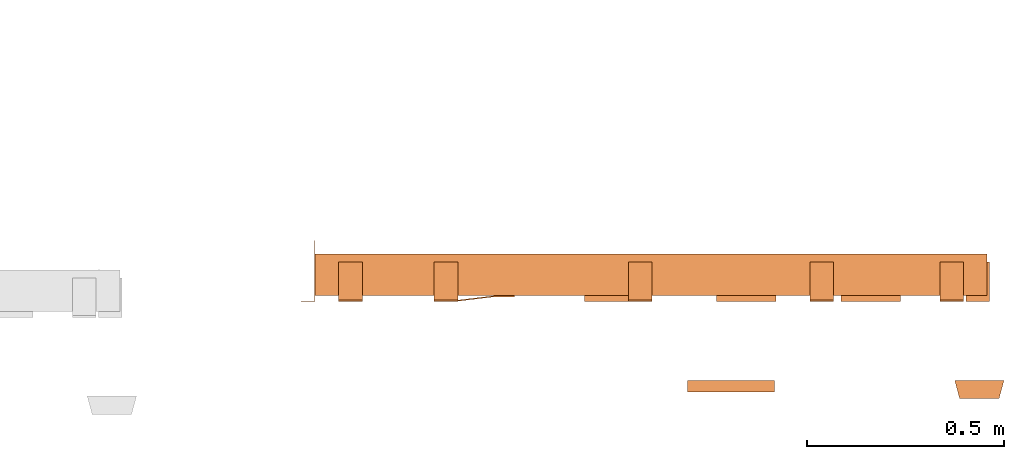
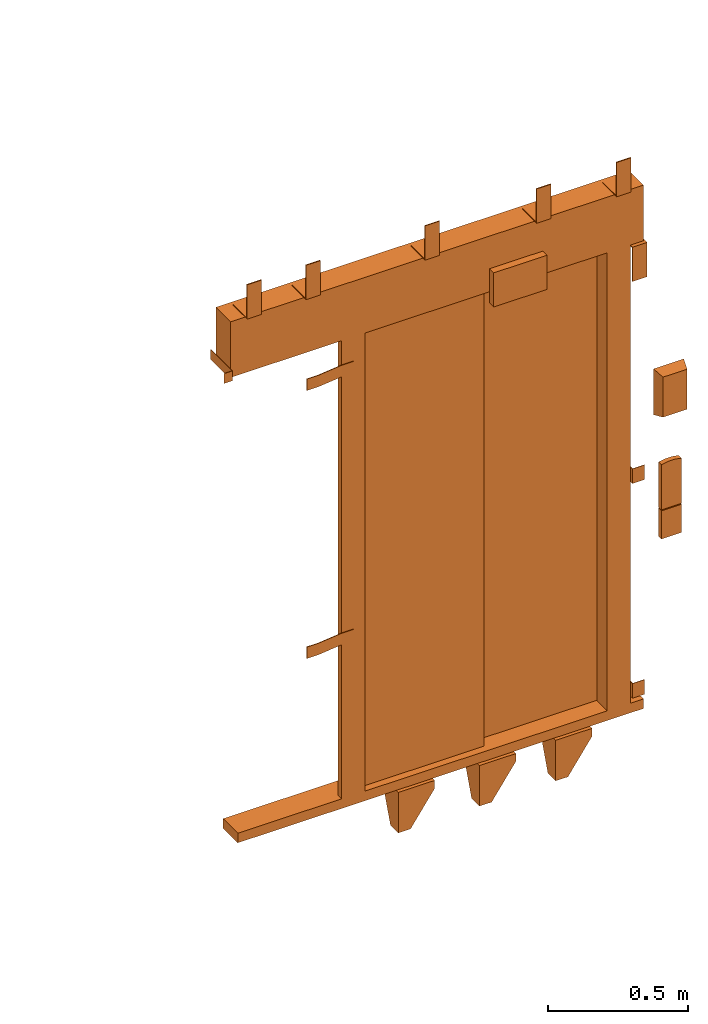
# One storey, part 2 of 2: 1 proxy.
"""IFC2X3 building model written with IfcOpenShell, lengths in millimetres."""

import ifcopenshell
import ifcopenshell.guid

model = None  # the IFC model being written
_history = None  # IfcOwnerHistory: only IFC2X3 demands one
_inside = {}  # id of a spatial element -> (the spatial element, [elements in it])
_under = {}  # id of a project, library or spatial element -> (it, [spatial elements below it])
_declared = {}  # id of a project -> (the project, [libraries it declares])
_typed = {}  # id of a type object -> (the type object, [elements of that type])
_made_of = {}  # id of a material, layer set ... -> (it, [elements and type objects made of it])


def new_model(schema):
    """Start an empty IFC model of exactly this schema.

    Asked for "IFC4X3", IfcOpenShell would pick the latest addendum, in which some entities
    have other attributes; the version numbers below select the first issue.
    IFC2X3 requires an IfcOwnerHistory on every rooted entity: one is made here for all.
    """
    global model, _history
    if schema == "IFC4X3":
        model = ifcopenshell.file(schema_version=(4, 3, 0, 0))
    else:
        model = ifcopenshell.file(schema=schema)
    _inside.clear()
    _under.clear()
    _declared.clear()
    _typed.clear()
    _made_of.clear()
    _history = None
    if model.schema == "IFC2X3":
        org = make("IfcOrganization", Name="unknown")
        user = make(
            "IfcPersonAndOrganization",
            ThePerson=make("IfcPerson", FamilyName="unknown"),
            TheOrganization=org,
        )
        app = make(
            "IfcApplication",
            ApplicationDeveloper=org,
            Version="unknown",
            ApplicationFullName="unknown",
            ApplicationIdentifier="unknown",
        )
        _history = make(
            "IfcOwnerHistory",
            OwningUser=user,
            OwningApplication=app,
            ChangeAction="ADDED",
            CreationDate=0,
        )
    return model


def make(cls, **values):
    """One entity of the class cls with the attributes given. An attribute that is None is left unset."""
    return model.create_entity(
        cls, **{name: value for name, value in values.items() if value is not None}
    )


def entity(cls, *values):
    """Any entity or typed value of the class cls, its attributes in the order of the schema. None: left unset."""
    e = model.create_entity(cls)
    for i, value in enumerate(values):
        if value is not None:
            e[i] = value
    return e


def rooted(cls, **values):
    """An entity with a GlobalId (a new one), such as an element, a storey or a relation."""
    return make(cls, GlobalId=ifcopenshell.guid.new(), OwnerHistory=_history, **values)


def si_unit(unit_type, name, prefix=None):
    """IfcSIUnit, for example si_unit("LENGTHUNIT", "METRE", prefix="MILLI")."""
    return make("IfcSIUnit", UnitType=unit_type, Prefix=prefix, Name=name)


def converted_unit(unit_type, name, factor, base, dimensions=None, offset=None):
    """IfcConversionBasedUnit, such as the inch: factor (a typed value) times the base unit."""
    return make(
        "IfcConversionBasedUnit"
        if offset is None
        else "IfcConversionBasedUnitWithOffset",
        ConversionOffset=offset,
        Dimensions=None
        if dimensions is None
        else entity("IfcDimensionalExponents", *dimensions),
        UnitType=unit_type,
        Name=name,
        ConversionFactor=make(
            "IfcMeasureWithUnit", ValueComponent=factor, UnitComponent=base
        ),
    )


def derived_unit(unit_type, elements):
    """IfcDerivedUnit: a product of units, each with its exponent."""
    return make(
        "IfcDerivedUnit",
        Elements=[
            make("IfcDerivedUnitElement", Unit=unit, Exponent=power)
            for unit, power in elements
        ],
        UnitType=unit_type,
    )


def assignment(units):
    """IfcUnitAssignment: the units of a project."""
    return None if units is None else make("IfcUnitAssignment", Units=units)


def point(xyz):
    """IfcCartesianPoint."""
    return None if xyz is None else make("IfcCartesianPoint", Coordinates=xyz)


def direction(xyz):
    """IfcDirection."""
    return None if xyz is None else make("IfcDirection", DirectionRatios=xyz)


def frame(location, z_axis=None, x_axis=None):
    """IfcAxis2Placement3D, a coordinate frame: its origin and axes. An axis left out is left unset."""
    return make(
        "IfcAxis2Placement3D",
        Location=point(location),
        Axis=direction(z_axis),
        RefDirection=direction(x_axis),
    )


def origin():
    """The frame at (0, 0, 0) with its axes left unset."""
    return frame((0.0, 0.0, 0.0))


def place(relative_to, where):
    """IfcLocalPlacement: puts the frame where relative to a parent placement (None: the world)."""
    return make(
        "IfcLocalPlacement", PlacementRelTo=relative_to, RelativePlacement=where
    )


def context(
    kind, dimensions, precision=None, world=None, true_north=None, identifier=None
):
    """IfcGeometricRepresentationContext, for example the 3D "Model" context."""
    return make(
        "IfcGeometricRepresentationContext",
        ContextIdentifier=identifier,
        ContextType=kind,
        CoordinateSpaceDimension=dimensions,
        Precision=precision,
        WorldCoordinateSystem=world,
        TrueNorth=true_north,
    )


def subcontext(parent, identifier, kind, view, scale=None):
    """IfcGeometricRepresentationSubContext, for example "Body" below "Model"."""
    return make(
        "IfcGeometricRepresentationSubContext",
        ContextIdentifier=identifier,
        ContextType=kind,
        ParentContext=parent,
        TargetScale=scale,
        TargetView=view,
    )


def project(units=None, contexts=None):
    """IfcProject with its units and contexts."""
    return rooted(
        "IfcProject",
        Name="project",
        RepresentationContexts=contexts,
        UnitsInContext=assignment(units),
    )


def spatial(cls, under=None, at=None, **own):
    """A site, building, storey or space (cls), placed at a placement, below another one or the project."""
    s = rooted(cls, ObjectPlacement=at, **own)
    if under is not None:
        _under.setdefault(under.id(), (under, []))[1].append(s)
    return s


def faces_of(points, faces, orient=None, outer=None):
    """IfcFace entities. A face is a list of loops; a loop is a list of indices into points, from 0.

    orient and outer hold one flag for each loop. By default every Orientation is true, the
    first loop of a face is its IfcFaceOuterBound and the others are IfcFaceBound.
    """
    made = []
    for i, loops in enumerate(faces):
        bounds = []
        for j, loop in enumerate(loops):
            is_outer = j == 0 if outer is None else outer[i][j]
            bounds.append(
                make(
                    "IfcFaceOuterBound" if is_outer else "IfcFaceBound",
                    Bound=make("IfcPolyLoop", Polygon=[points[k] for k in loop]),
                    Orientation=True if orient is None else orient[i][j],
                )
            )
        made.append(make("IfcFace", Bounds=bounds))
    return made


def faceted_brep(points, faces, orient=None, outer=None, voids=None):
    """IfcFacetedBrep: a solid bounded by flat faces; with voids (closed shells), ...WithVoids."""
    shared = [point(p) for p in points]
    hull = make("IfcClosedShell", CfsFaces=faces_of(shared, faces, orient, outer))
    if voids is None:
        return make("IfcFacetedBrep", Outer=hull)
    return make(
        "IfcFacetedBrepWithVoids",
        Outer=hull,
        Voids=[
            make(cls, CfsFaces=faces_of(shared, fs, o, b)) for cls, fs, o, b in voids
        ],
    )


def shape(context_of_items, identifier, shape_type, items):
    """IfcShapeRepresentation: the items that make up one representation, for example the "Body"."""
    return make(
        "IfcShapeRepresentation",
        ContextOfItems=context_of_items,
        RepresentationIdentifier=identifier,
        RepresentationType=shape_type,
        Items=items,
    )


def source(mapping_origin, context_of_items, identifier, shape_type, items):
    """IfcRepresentationMap: a shape defined once, which mapped items show again and again."""
    return make(
        "IfcRepresentationMap",
        MappingOrigin=mapping_origin,
        MappedRepresentation=shape(context_of_items, identifier, shape_type, items),
    )


def transform(
    local_origin,
    x_axis=None,
    y_axis=None,
    z_axis=None,
    scale=None,
    scale2=None,
    scale3=None,
    uniform=True,
):
    """IfcCartesianTransformationOperator3D, or its non-uniform kind. x_axis, y_axis, z_axis: its Axis1, 2, 3."""
    if uniform:
        return make(
            "IfcCartesianTransformationOperator3D",
            Axis1=direction(x_axis),
            Axis2=direction(y_axis),
            LocalOrigin=point(local_origin),
            Scale=scale,
            Axis3=direction(z_axis),
        )
    return make(
        "IfcCartesianTransformationOperator3DnonUniform",
        Axis1=direction(x_axis),
        Axis2=direction(y_axis),
        LocalOrigin=point(local_origin),
        Scale=scale,
        Axis3=direction(z_axis),
        Scale2=scale2,
        Scale3=scale3,
    )


def mapped(mapping_source, mapping_target):
    """IfcMappedItem: shows the shape of a source again, moved by a transform."""
    return make(
        "IfcMappedItem", MappingSource=mapping_source, MappingTarget=mapping_target
    )


def material(Name=None, Category=None):
    """IfcMaterial."""
    return make("IfcMaterial", Name=Name, Category=Category)


def made_of(thing, what):
    """Note that an element or type object is made of a material, layer set ...; save() writes the relation."""
    if what is not None:
        _made_of.setdefault(what.id(), (what, []))[1].append(thing)
    return thing


def type_object(cls, material=None, **own):
    """A type object (cls), such as IfcWallType, which elements share."""
    return made_of(rooted(cls, **own), material)


def type_shapes(of_type, sources):
    """Give a type object the sources (RepresentationMaps) that its elements show as mapped items."""
    of_type.RepresentationMaps = sources


def element(
    cls,
    number,
    at=None,
    inside=None,
    cuts=None,
    type_object=None,
    material=None,
    context=None,
    identifier="Body",
    shape_type=None,
    held_by="IfcProductDefinitionShape",
    body=None,
    shapes=None,
    **own,
):
    """One element of the class cls, such as IfcWall. Its Tag is "e" and its number.

    at: its placement. inside: the storey or other place that contains it. cuts: it is an
    opening in that element (IfcRelVoidsElement). A single representation is given by context,
    identifier, shape_type and body (its items); several are given by shapes. held_by: the class
    of the entity that holds the representations. save() writes the other relations.
    """
    e = rooted(cls, Tag="e%d" % number, ObjectPlacement=at, **own)
    if body is not None:
        shapes = [shape(context, identifier, shape_type, body)]
    if shapes is not None:
        e.Representation = make(held_by, Representations=shapes)
    if inside is not None:
        _inside.setdefault(inside.id(), (inside, []))[1].append(e)
    if cuts is not None:
        rooted(
            "IfcRelVoidsElement", RelatingBuildingElement=cuts, RelatedOpeningElement=e
        )
    if type_object is not None:
        _typed.setdefault(type_object.id(), (type_object, []))[1].append(e)
    return made_of(e, material)


def aggregate(whole, parts):
    """IfcRelAggregates: a whole, such as a stair, and the parts it consists of."""
    return rooted("IfcRelAggregates", RelatingObject=whole, RelatedObjects=parts)


def save(model, path):
    """Write the relations noted so far, then the file.

    IfcRelAggregates (storeys below a building ...), IfcRelContainedInSpatialStructure (elements
    in a storey), IfcRelDefinesByType, IfcRelAssociatesMaterial and IfcRelDeclares: one each for
    every whole, place, type object, material and project.
    """
    for whole, parts in _under.values():
        aggregate(whole, parts)
    for where, things in _inside.values():
        rooted(
            "IfcRelContainedInSpatialStructure",
            RelatedElements=things,
            RelatingStructure=where,
        )
    for kind, things in _typed.values():
        rooted("IfcRelDefinesByType", RelatedObjects=things, RelatingType=kind)
    for what, things in _made_of.values():
        rooted("IfcRelAssociatesMaterial", RelatedObjects=things, RelatingMaterial=what)
    for by, libraries in _declared.values():
        rooted("IfcRelDeclares", RelatingContext=by, RelatedDefinitions=libraries)
    model.write(path)


model = new_model("IFC2X3")

# Units and contexts
model_context = context("Model", 3, precision=0.01, world=origin(), true_north=direction((6.12303176911189e-17, 1.0)))
body_context = subcontext(model_context, "Body", "Model", "MODEL_VIEW")
ifc_project = project(units=[si_unit("LENGTHUNIT", "METRE", prefix="MILLI"), si_unit("AREAUNIT", "SQUARE_METRE"), si_unit("VOLUMEUNIT", "CUBIC_METRE"), converted_unit("PLANEANGLEUNIT", "DEGREE", entity("IfcRatioMeasure", 0.0174532925199433), si_unit("PLANEANGLEUNIT", "RADIAN"), dimensions=[0, 0, 0, 0, 0, 0, 0]), si_unit("MASSUNIT", "GRAM", prefix="KILO"), derived_unit("MASSDENSITYUNIT", [(si_unit("MASSUNIT", "GRAM", prefix="KILO"), 1), (si_unit("LENGTHUNIT", "METRE"), -3)]), derived_unit("MOMENTOFINERTIAUNIT", [(si_unit("LENGTHUNIT", "METRE"), 4)]), si_unit("TIMEUNIT", "SECOND"), si_unit("FREQUENCYUNIT", "HERTZ"), si_unit("THERMODYNAMICTEMPERATUREUNIT", "DEGREE_CELSIUS"), derived_unit("THERMALTRANSMITTANCEUNIT", [(si_unit("MASSUNIT", "GRAM", prefix="KILO"), 1), (si_unit("THERMODYNAMICTEMPERATUREUNIT", "KELVIN"), -1), (si_unit("TIMEUNIT", "SECOND"), -3)]), derived_unit("VOLUMETRICFLOWRATEUNIT", [(si_unit("LENGTHUNIT", "METRE"), 3), (si_unit("TIMEUNIT", "SECOND"), -1)]), derived_unit("MASSFLOWRATEUNIT", [(si_unit("MASSUNIT", "GRAM", prefix="KILO"), 1), (si_unit("TIMEUNIT", "SECOND"), -1)]), derived_unit("ROTATIONALFREQUENCYUNIT", [(si_unit("TIMEUNIT", "SECOND"), -1)]), si_unit("ELECTRICCURRENTUNIT", "AMPERE"), si_unit("ELECTRICVOLTAGEUNIT", "VOLT"), si_unit("POWERUNIT", "WATT"), si_unit("FORCEUNIT", "NEWTON", prefix="KILO"), si_unit("ILLUMINANCEUNIT", "LUX"), si_unit("LUMINOUSFLUXUNIT", "LUMEN"), si_unit("LUMINOUSINTENSITYUNIT", "CANDELA"), derived_unit("USERDEFINED", [(si_unit("MASSUNIT", "GRAM", prefix="KILO"), -1), (si_unit("LENGTHUNIT", "METRE"), -2), (si_unit("TIMEUNIT", "SECOND"), 3), (si_unit("LUMINOUSFLUXUNIT", "LUMEN"), 1)]), derived_unit("LINEARVELOCITYUNIT", [(si_unit("LENGTHUNIT", "METRE"), 1), (si_unit("TIMEUNIT", "SECOND"), -1)]), si_unit("PRESSUREUNIT", "PASCAL"), derived_unit("USERDEFINED", [(si_unit("LENGTHUNIT", "METRE"), -2), (si_unit("MASSUNIT", "GRAM", prefix="KILO"), 1), (si_unit("TIMEUNIT", "SECOND"), -2)]), derived_unit("LINEARFORCEUNIT", [(si_unit("MASSUNIT", "GRAM", prefix="KILO"), 1), (si_unit("LENGTHUNIT", "METRE"), 1), (si_unit("TIMEUNIT", "SECOND"), -2), (si_unit("LENGTHUNIT", "METRE"), -1)]), derived_unit("PLANARFORCEUNIT", [(si_unit("MASSUNIT", "GRAM", prefix="KILO"), 1), (si_unit("LENGTHUNIT", "METRE"), 1), (si_unit("TIMEUNIT", "SECOND"), -2), (si_unit("LENGTHUNIT", "METRE"), -2)])], contexts=[model_context])

# Site, building, storey
site_placement = place(None, origin())
site = spatial("IfcSite", under=ifc_project, at=site_placement, CompositionType="ELEMENT")
building_placement = place(site_placement, origin())
building = spatial("IfcBuilding", under=site, at=building_placement, CompositionType="ELEMENT")
storey_placement = place(building_placement, frame((0.0, 0.0, 19800.0)))
storey = spatial("IfcBuildingStorey", under=building, at=storey_placement, CompositionType="ELEMENT", Elevation=19800.0)

# Proxy
ifc_material = material()
building_element_proxy_type = type_object("IfcBuildingElementProxyType", PredefinedType="NOTDEFINED", material=ifc_material)
shared_shape = source(origin(), body_context, "Body", "Brep", [
    faceted_brep([(11.67, 105.0, -47.0), (114.5, 33.0, -47.0), (114.5, 5.0, -47.0), (-31.0, 5.0, -47.0), (-31.0, 105.0, -47.0), (11.67, 105.0, -42.0), (-36.0, 105.0, -42.0), (-36.0, 0.0, -42.0), (114.5, 0.0, -42.0), (114.5, 33.0, -42.0), (-31.0, 105.0, -84.0), (-36.0, 105.0, -84.0), (-36.0, 55.86, -219.0), (-36.0, 0.0, -219.0), (114.5, 0.0, -76.19), (114.5, 5.0, -76.19), (14.5, 5.0, -219.0), (-31.0, 5.0, -219.0), (14.5, 0.0, -219.0), (-31.0, 55.86, -219.0)], [[[0, 1, 2, 3, 4]], [[5, 6, 7, 8, 9]], [[6, 5, 0, 4, 10, 11]], [[6, 11, 12, 13, 7]], [[2, 1, 9, 8, 14, 15]], [[1, 0, 5, 9]], [[15, 16, 17, 3, 2]], [[7, 13, 18, 14, 8]], [[16, 15, 14, 18]], [[18, 13, 12, 19, 17, 16]], [[19, 10, 4, 3, 17]], [[12, 11, 10, 19]]]),
    faceted_brep([(-1090.0, 1.5, 2038.5), (-1090.0, 0.0, 2038.5), (-1055.0, 0.0, 2038.5), (-1055.0, 155.0, 2038.5), (-1056.5, 155.0, 2038.5), (-1056.5, 1.5, 2038.5), (-1090.0, 1.5, 1995.5), (-1056.5, 1.5, 1995.5), (-1056.5, 155.0, 1995.5), (-1055.0, 155.0, 1995.5), (-1055.0, 0.0, 1995.5), (-1090.0, 0.0, 1995.5)], [[[0, 1, 2, 3, 4, 5]], [[6, 7, 8, 9, 10, 11]], [[1, 0, 6, 11]], [[2, 1, 11, 10]], [[3, 2, 10, 9]], [[4, 3, 9, 8]], [[5, 4, 8, 7]], [[0, 5, 7, 6]]]),
    faceted_brep([(-749.0, 3.0, 1895.0), (-749.0, 0.0, 1895.0), (-699.0, 0.0, 1895.0), (-599.0, 12.0, 1895.0), (-549.0, 12.0, 1895.0), (-549.0, 15.0, 1895.0), (-599.0, 15.0, 1895.0), (-699.0, 3.0, 1895.0), (-749.0, 3.0, 1845.0), (-699.0, 3.0, 1845.0), (-599.0, 15.0, 1845.0), (-549.0, 15.0, 1845.0), (-549.0, 12.0, 1845.0), (-599.0, 12.0, 1845.0), (-699.0, 0.0, 1845.0), (-749.0, 0.0, 1845.0)], [[[0, 1, 2, 3, 4, 5, 6, 7]], [[8, 9, 10, 11, 12, 13, 14, 15]], [[1, 0, 8, 15]], [[2, 1, 15, 14]], [[3, 2, 14, 13]], [[4, 3, 13, 12]], [[5, 4, 12, 11]], [[6, 5, 11, 10]], [[7, 6, 10, 9]], [[0, 7, 9, 8]]]),
    faceted_brep([(-749.0, 3.0, 725.0), (-749.0, 0.0, 725.0), (-699.0, 0.0, 725.0), (-599.0, 12.0, 725.0), (-549.0, 12.0, 725.0), (-549.0, 15.0, 725.0), (-599.0, 15.0, 725.0), (-699.0, 3.0, 725.0), (-749.0, 3.0, 675.0), (-699.0, 3.0, 675.0), (-599.0, 15.0, 675.0), (-549.0, 15.0, 675.0), (-549.0, 12.0, 675.0), (-599.0, 12.0, 675.0), (-699.0, 0.0, 675.0), (-749.0, 0.0, 675.0)], [[[0, 1, 2, 3, 4, 5, 6, 7]], [[8, 9, 10, 11, 12, 13, 14, 15]], [[1, 0, 8, 15]], [[2, 1, 15, 14]], [[3, 2, 14, 13]], [[4, 3, 13, 12]], [[5, 4, 12, 11]], [[6, 5, 11, 10]], [[7, 6, 10, 9]], [[0, 7, 9, 8]]]),
    faceted_brep([(596.0, 121.0, 95.0), (596.0, 0.0, 95.0), (646.0, 0.0, 95.0), (646.0, 2.0, 95.0), (598.0, 2.0, 95.0), (598.0, 121.0, 95.0), (596.0, 121.0, 31.0), (598.0, 121.0, 31.0), (598.0, 2.0, 31.0), (646.0, 2.0, 31.0), (646.0, 0.0, 31.0), (596.0, 0.0, 31.0)], [[[0, 1, 2, 3, 4, 5]], [[6, 7, 8, 9, 10, 11]], [[1, 0, 6, 11]], [[2, 1, 11, 10]], [[3, 2, 10, 9]], [[4, 3, 9, 8]], [[5, 4, 8, 7]], [[0, 5, 7, 6]]]),
    faceted_brep([(596.0, 121.0, 1032.0), (596.0, 0.0, 1032.0), (646.0, 0.0, 1032.0), (646.0, 2.0, 1032.0), (598.0, 2.0, 1032.0), (598.0, 121.0, 1032.0), (596.0, 121.0, 968.0), (598.0, 121.0, 968.0), (598.0, 2.0, 968.0), (646.0, 2.0, 968.0), (646.0, 0.0, 968.0), (596.0, 0.0, 968.0)], [[[0, 1, 2, 3, 4, 5]], [[6, 7, 8, 9, 10, 11]], [[1, 0, 6, 11]], [[2, 1, 11, 10]], [[3, 2, 10, 9]], [[4, 3, 9, 8]], [[5, 4, 8, 7]], [[0, 5, 7, 6]]]),
    faceted_brep([(326.67, 105.0, -47.0), (429.5, 33.0, -47.0), (429.5, 5.0, -47.0), (284.0, 5.0, -47.0), (284.0, 105.0, -47.0), (326.67, 105.0, -42.0), (279.0, 105.0, -42.0), (279.0, 0.0, -42.0), (429.5, 0.0, -42.0), (429.5, 33.0, -42.0), (284.0, 105.0, -84.0), (279.0, 105.0, -84.0), (279.0, 55.86, -219.0), (279.0, 0.0, -219.0), (429.5, 0.0, -76.19), (429.5, 5.0, -76.19), (329.5, 5.0, -219.0), (284.0, 5.0, -219.0), (329.5, 0.0, -219.0), (284.0, 55.86, -219.0)], [[[0, 1, 2, 3, 4]], [[5, 6, 7, 8, 9]], [[6, 5, 0, 4, 10, 11]], [[6, 11, 12, 13, 7]], [[2, 1, 9, 8, 14, 15]], [[1, 0, 5, 9]], [[15, 16, 17, 3, 2]], [[7, 13, 18, 14, 8]], [[16, 15, 14, 18]], [[18, 13, 12, 19, 17, 16]], [[19, 10, 4, 3, 17]], [[12, 11, 10, 19]]]),
    faceted_brep([(-323.33, 105.0, -47.0), (-220.5, 33.0, -47.0), (-220.5, 5.0, -47.0), (-366.0, 5.0, -47.0), (-366.0, 105.0, -47.0), (-323.33, 105.0, -42.0), (-371.0, 105.0, -42.0), (-371.0, 0.0, -42.0), (-220.5, 0.0, -42.0), (-220.5, 33.0, -42.0), (-366.0, 105.0, -84.0), (-371.0, 105.0, -84.0), (-371.0, 55.86, -219.0), (-371.0, 0.0, -219.0), (-220.5, 0.0, -76.19), (-220.5, 5.0, -76.19), (-320.5, 5.0, -219.0), (-366.0, 5.0, -219.0), (-320.5, 0.0, -219.0), (-366.0, 55.86, -219.0)], [[[0, 1, 2, 3, 4]], [[5, 6, 7, 8, 9]], [[6, 5, 0, 4, 10, 11]], [[6, 11, 12, 13, 7]], [[2, 1, 9, 8, 14, 15]], [[1, 0, 5, 9]], [[15, 16, 17, 3, 2]], [[7, 13, 18, 14, 8]], [[16, 15, 14, 18]], [[18, 13, 12, 19, 17, 16]], [[19, 10, 4, 3, 17]], [[12, 11, 10, 19]]]),
    faceted_brep([(656.0, 100.0, 2000.0), (656.0, 0.0, 2000.0), (656.0, 0.0, 1850.0), (656.0, 4.0, 1850.0), (656.0, 4.0, 1996.0), (656.0, 100.0, 1996.0), (596.0, 100.0, 2000.0), (596.0, 100.0, 1996.0), (596.0, 4.0, 1996.0), (596.0, 4.0, 1850.0), (596.0, 0.0, 1850.0), (596.0, 0.0, 2000.0)], [[[0, 1, 2, 3, 4, 5]], [[6, 7, 8, 9, 10, 11]], [[1, 0, 6, 11]], [[2, 1, 11, 10]], [[3, 2, 10, 9]], [[4, 3, 9, 8]], [[5, 4, 8, 7]], [[0, 5, 7, 6]]]),
    faceted_brep([(590.0, 100.0, 2247.0), (590.0, 4.0, 2247.0), (590.0, 4.0, 2393.0), (590.0, 0.0, 2393.0), (590.0, 0.0, 2243.0), (590.0, 100.0, 2243.0), (530.0, 100.0, 2247.0), (530.0, 100.0, 2243.0), (530.0, 0.0, 2243.0), (530.0, 0.0, 2393.0), (530.0, 4.0, 2393.0), (530.0, 4.0, 2247.0)], [[[0, 1, 2, 3, 4, 5]], [[6, 7, 8, 9, 10, 11]], [[1, 0, 6, 11]], [[2, 1, 11, 10]], [[3, 2, 10, 9]], [[4, 3, 9, 8]], [[5, 4, 8, 7]], [[0, 5, 7, 6]]]),
    faceted_brep([(-200.0, 100.0, 2247.0), (-200.0, 4.0, 2247.0), (-200.0, 4.0, 2393.0), (-200.0, 0.0, 2393.0), (-200.0, 0.0, 2243.0), (-200.0, 100.0, 2243.0), (-260.0, 100.0, 2247.0), (-260.0, 100.0, 2243.0), (-260.0, 0.0, 2243.0), (-260.0, 0.0, 2393.0), (-260.0, 4.0, 2393.0), (-260.0, 4.0, 2247.0)], [[[0, 1, 2, 3, 4, 5]], [[6, 7, 8, 9, 10, 11]], [[1, 0, 6, 11]], [[2, 1, 11, 10]], [[3, 2, 10, 9]], [[4, 3, 9, 8]], [[5, 4, 8, 7]], [[0, 5, 7, 6]]]),
    faceted_brep([(-692.5, 100.0, 2247.0), (-692.5, 4.0, 2247.0), (-692.5, 4.0, 2393.0), (-692.5, 0.0, 2393.0), (-692.5, 0.0, 2243.0), (-692.5, 100.0, 2243.0), (-752.5, 100.0, 2247.0), (-752.5, 100.0, 2243.0), (-752.5, 0.0, 2243.0), (-752.5, 0.0, 2393.0), (-752.5, 4.0, 2393.0), (-752.5, 4.0, 2247.0)], [[[0, 1, 2, 3, 4, 5]], [[6, 7, 8, 9, 10, 11]], [[1, 0, 6, 11]], [[2, 1, 11, 10]], [[3, 2, 10, 9]], [[4, 3, 9, 8]], [[5, 4, 8, 7]], [[0, 5, 7, 6]]]),
    faceted_brep([(-935.0, 100.0, 2247.0), (-935.0, 4.0, 2247.0), (-935.0, 4.0, 2393.0), (-935.0, 0.0, 2393.0), (-935.0, 0.0, 2243.0), (-935.0, 100.0, 2243.0), (-995.0, 100.0, 2247.0), (-995.0, 100.0, 2243.0), (-995.0, 0.0, 2243.0), (-995.0, 0.0, 2393.0), (-995.0, 4.0, 2393.0), (-995.0, 4.0, 2247.0)], [[[0, 1, 2, 3, 4, 5]], [[6, 7, 8, 9, 10, 11]], [[1, 0, 6, 11]], [[2, 1, 11, 10]], [[3, 2, 10, 9]], [[4, 3, 9, 8]], [[5, 4, 8, 7]], [[0, 5, 7, 6]]]),
    faceted_brep([(260.0, 100.0, 2247.0), (260.0, 4.0, 2247.0), (260.0, 4.0, 2393.0), (260.0, 0.0, 2393.0), (260.0, 0.0, 2243.0), (260.0, 100.0, 2243.0), (200.0, 100.0, 2247.0), (200.0, 100.0, 2243.0), (200.0, 0.0, 2243.0), (200.0, 0.0, 2393.0), (200.0, 4.0, 2393.0), (200.0, 4.0, 2247.0)], [[[0, 1, 2, 3, 4, 5]], [[6, 7, 8, 9, 10, 11]], [[1, 0, 6, 11]], [[2, 1, 11, 10]], [[3, 2, 10, 9]], [[4, 3, 9, 8]], [[5, 4, 8, 7]], [[0, 5, 7, 6]]]),
    faceted_brep([(680.0, -246.0, 1587.5), (580.0, -246.0, 1587.5), (580.0, -246.0, 1412.5), (680.0, -246.0, 1412.5), (692.5, -200.0, 1600.0), (692.5, -200.0, 1400.0), (567.5, -200.0, 1400.0), (567.5, -200.0, 1600.0)], [[[0, 1, 2, 3]], [[4, 5, 6, 7]], [[4, 7, 1, 0]], [[7, 6, 2, 1]], [[6, 5, 3, 2]], [[5, 4, 0, 3]]]),
    faceted_brep([(671.5, -220.0, 985.0), (588.5, -220.0, 985.0), (588.5, -220.0, 862.0), (671.5, -220.0, 862.0), (671.5, -200.0, 985.0), (671.5, -200.0, 862.0), (588.5, -200.0, 862.0), (588.5, -200.0, 985.0)], [[[0, 1, 2, 3]], [[4, 5, 6, 7]], [[1, 0, 4, 7]], [[2, 1, 7, 6]], [[3, 2, 6, 5]], [[0, 3, 5, 4]]]),
    faceted_brep([(110.0, -200.0, 2274.5), (110.0, -200.0, 2125.5), (-110.0, -200.0, 2125.5), (-110.0, -200.0, 2274.5), (110.0, -230.0, 2274.5), (-110.0, -230.0, 2274.5), (-110.0, -230.0, 2125.5), (110.0, -230.0, 2125.5)], [[[0, 1, 2, 3]], [[4, 5, 6, 7]], [[5, 4, 0, 3]], [[6, 5, 3, 2]], [[7, 6, 2, 1]], [[4, 7, 1, 0]]]),
    faceted_brep([(644.0, -220.0, 1191.35), (616.0, -220.0, 1191.35), (588.5, -220.0, 1186.14), (588.5, -220.0, 989.0), (671.5, -220.0, 989.0), (671.5, -220.0, 1186.14), (671.5, -200.0, 1186.14), (671.5, -200.0, 989.0), (588.5, -200.0, 989.0), (588.5, -200.0, 1186.14), (616.0, -200.0, 1191.35), (644.0, -200.0, 1191.35)], [[[0, 1, 2, 3, 4, 5]], [[6, 7, 8, 9, 10, 11]], [[3, 2, 9, 8]], [[4, 3, 8, 7]], [[5, 4, 7, 6]], [[6, 11, 0, 5]], [[11, 10, 1, 0]], [[10, 9, 2, 1]]]),
    faceted_brep([(500.0, 87.0, 2000.0), (500.0, 15.0, 2000.0), (596.0, 15.0, 2000.0), (596.0, 120.0, 2000.0), (519.0, 120.0, 2000.0), (519.0, 87.0, 2000.0), (500.0, 87.0, 0.0), (500.0, 15.0, 0.0), (596.0, 15.0, 0.0), (596.0, 120.0, 0.0), (519.0, 120.0, 0.0), (519.0, 87.0, 0.0)], [[[0, 1, 2, 3, 4, 5]], [[1, 0, 6, 7]], [[2, 1, 7, 8]], [[3, 2, 8, 9]], [[4, 3, 9, 10]], [[5, 4, 10, 11]], [[0, 5, 11, 6]], [[6, 11, 10, 9, 8, 7]]]),
    faceted_brep([(-500.0, 41.0, 0.0), (-500.0, 15.0, 0.0), (-596.0, 15.0, 0.0), (-596.0, 41.0, 0.0), (-596.0, 41.0, 2000.0), (-500.0, 41.0, 2000.0), (-596.0, 15.0, 2000.0), (-500.0, 15.0, 2000.0)], [[[0, 1, 2, 3]], [[4, 5, 0, 3]], [[6, 4, 3, 2]], [[7, 6, 2, 1]], [[5, 7, 1, 0]], [[5, 4, 6, 7]]]),
    faceted_brep([(650.0, 15.0, 0.0), (650.0, 15.0, -42.0), (650.0, 120.0, -42.0), (650.0, 120.0, 0.0), (-1025.0, 15.0, 0.0), (-1025.0, 120.0, 0.0), (-1025.0, 120.0, -42.0), (-1025.0, 15.0, -42.0)], [[[0, 1, 2, 3]], [[4, 5, 6, 7]], [[1, 0, 4, 7]], [[2, 1, 7, 6]], [[3, 2, 6, 5]], [[0, 3, 5, 4]]]),
    faceted_brep([(650.0, 15.0, 2243.0), (650.0, 15.0, 2000.0), (650.0, 120.0, 2000.0), (650.0, 120.0, 2243.0), (-1055.0, 15.0, 2243.0), (-1055.0, 120.0, 2243.0), (-1055.0, 120.0, 2000.0), (-1055.0, 15.0, 2000.0)], [[[0, 1, 2, 3]], [[4, 5, 6, 7]], [[1, 0, 4, 7]], [[2, 1, 7, 6]], [[3, 2, 6, 5]], [[0, 3, 5, 4]]]),
    faceted_brep([(515.0, 120.0, 2000.0), (-22.0, 120.0, 2000.0), (-22.0, 91.0, 2000.0), (515.0, 91.0, 2000.0), (515.0, 120.0, 0.0), (-22.0, 120.0, 0.0), (-22.0, 91.0, 0.0), (515.0, 91.0, 0.0)], [[[0, 1, 2, 3]], [[1, 0, 4, 5]], [[2, 1, 5, 6]], [[3, 2, 6, 7]], [[0, 3, 7, 4]], [[4, 7, 6, 5]]]),
    faceted_brep([(8.0, 87.0, 0.0), (8.0, 45.0, 0.0), (-530.0, 45.0, 0.0), (-530.0, 87.0, 0.0), (-530.0, 87.0, 2000.0), (8.0, 87.0, 2000.0), (-530.0, 45.0, 2000.0), (8.0, 45.0, 2000.0)], [[[0, 1, 2, 3]], [[4, 5, 0, 3]], [[6, 4, 3, 2]], [[7, 6, 2, 1]], [[5, 7, 1, 0]], [[5, 4, 6, 7]]]),
])
type_shapes(building_element_proxy_type, [shared_shape])
proxy_placement = place(storey_placement, frame((72363.25, 14180.0, -19800.0)))
element("IfcBuildingElementProxy", 1, at=proxy_placement, inside=storey, type_object=building_element_proxy_type, material=ifc_material, context=body_context, shape_type="MappedRepresentation", body=[
    mapped(shared_shape, transform((0.0, 0.0, 0.0), scale=1.0)),
])

save(model, "model.ifc")
